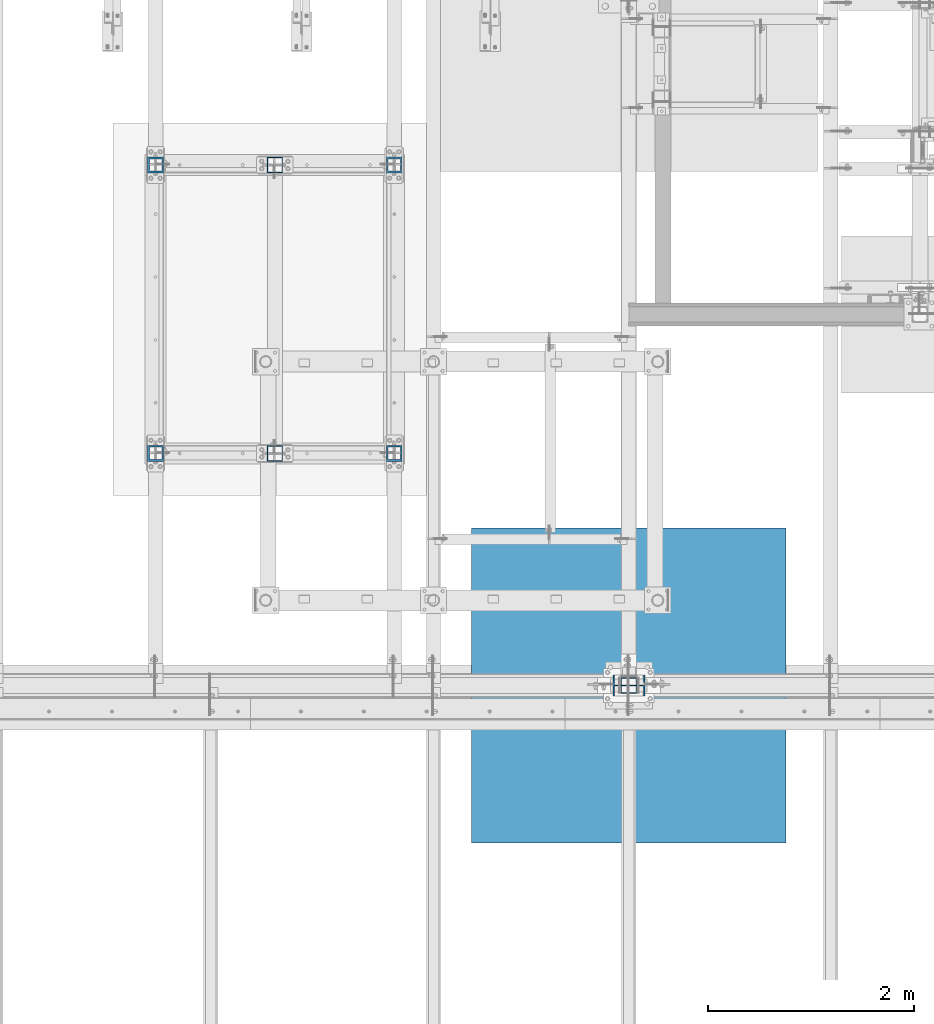
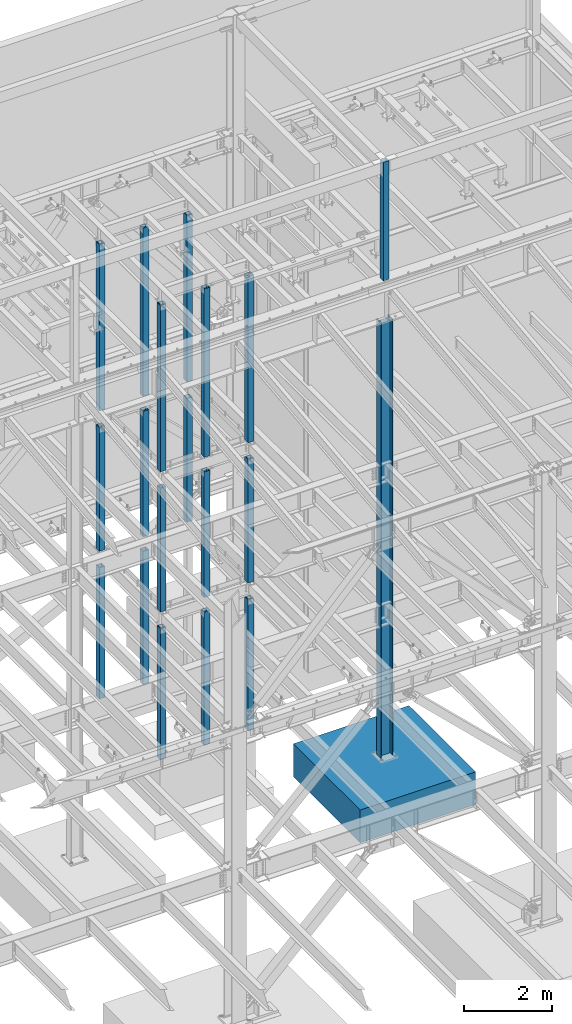
# One storey, part 370 of 1179: 20 columns, 20 elements without a shape of their own.
"""IFC2X3 building model written with IfcOpenShell, lengths in millimetres."""

import ifcopenshell
import ifcopenshell.guid

model = None  # the IFC model being written
_history = None  # IfcOwnerHistory: only IFC2X3 demands one
_inside = {}  # id of a spatial element -> (the spatial element, [elements in it])
_under = {}  # id of a project, library or spatial element -> (it, [spatial elements below it])
_declared = {}  # id of a project -> (the project, [libraries it declares])
_typed = {}  # id of a type object -> (the type object, [elements of that type])
_made_of = {}  # id of a material, layer set ... -> (it, [elements and type objects made of it])


def new_model(schema):
    """Start an empty IFC model of exactly this schema.

    Asked for "IFC4X3", IfcOpenShell would pick the latest addendum, in which some entities
    have other attributes; the version numbers below select the first issue.
    IFC2X3 requires an IfcOwnerHistory on every rooted entity: one is made here for all.
    """
    global model, _history
    if schema == "IFC4X3":
        model = ifcopenshell.file(schema_version=(4, 3, 0, 0))
    else:
        model = ifcopenshell.file(schema=schema)
    _inside.clear()
    _under.clear()
    _declared.clear()
    _typed.clear()
    _made_of.clear()
    _history = None
    if model.schema == "IFC2X3":
        org = make("IfcOrganization", Name="unknown")
        user = make(
            "IfcPersonAndOrganization",
            ThePerson=make("IfcPerson", FamilyName="unknown"),
            TheOrganization=org,
        )
        app = make(
            "IfcApplication",
            ApplicationDeveloper=org,
            Version="unknown",
            ApplicationFullName="unknown",
            ApplicationIdentifier="unknown",
        )
        _history = make(
            "IfcOwnerHistory",
            OwningUser=user,
            OwningApplication=app,
            ChangeAction="ADDED",
            CreationDate=0,
        )
    return model


def make(cls, **values):
    """One entity of the class cls with the attributes given. An attribute that is None is left unset."""
    return model.create_entity(
        cls, **{name: value for name, value in values.items() if value is not None}
    )


def rooted(cls, **values):
    """An entity with a GlobalId (a new one), such as an element, a storey or a relation."""
    return make(cls, GlobalId=ifcopenshell.guid.new(), OwnerHistory=_history, **values)


def si_unit(unit_type, name, prefix=None):
    """IfcSIUnit, for example si_unit("LENGTHUNIT", "METRE", prefix="MILLI")."""
    return make("IfcSIUnit", UnitType=unit_type, Prefix=prefix, Name=name)


def assignment(units):
    """IfcUnitAssignment: the units of a project."""
    return None if units is None else make("IfcUnitAssignment", Units=units)


def point(xyz):
    """IfcCartesianPoint."""
    return None if xyz is None else make("IfcCartesianPoint", Coordinates=xyz)


def direction(xyz):
    """IfcDirection."""
    return None if xyz is None else make("IfcDirection", DirectionRatios=xyz)


def frame(location, z_axis=None, x_axis=None):
    """IfcAxis2Placement3D, a coordinate frame: its origin and axes. An axis left out is left unset."""
    return make(
        "IfcAxis2Placement3D",
        Location=point(location),
        Axis=direction(z_axis),
        RefDirection=direction(x_axis),
    )


def origin_with_axes():
    """The frame at (0, 0, 0) with the z axis (0, 0, 1) and the x axis (1, 0, 0) written out."""
    return frame((0.0, 0.0, 0.0), z_axis=(0.0, 0.0, 1.0), x_axis=(1.0, 0.0, 0.0))


def place(relative_to, where):
    """IfcLocalPlacement: puts the frame where relative to a parent placement (None: the world)."""
    return make(
        "IfcLocalPlacement", PlacementRelTo=relative_to, RelativePlacement=where
    )


def context(
    kind, dimensions, precision=None, world=None, true_north=None, identifier=None
):
    """IfcGeometricRepresentationContext, for example the 3D "Model" context."""
    return make(
        "IfcGeometricRepresentationContext",
        ContextIdentifier=identifier,
        ContextType=kind,
        CoordinateSpaceDimension=dimensions,
        Precision=precision,
        WorldCoordinateSystem=world,
        TrueNorth=true_north,
    )


def subcontext(parent, identifier, kind, view, scale=None):
    """IfcGeometricRepresentationSubContext, for example "Body" below "Model"."""
    return make(
        "IfcGeometricRepresentationSubContext",
        ContextIdentifier=identifier,
        ContextType=kind,
        ParentContext=parent,
        TargetScale=scale,
        TargetView=view,
    )


def project(units=None, contexts=None):
    """IfcProject with its units and contexts."""
    return rooted(
        "IfcProject",
        Name="project",
        RepresentationContexts=contexts,
        UnitsInContext=assignment(units),
    )


def spatial(cls, under=None, at=None, **own):
    """A site, building, storey or space (cls), placed at a placement, below another one or the project."""
    s = rooted(cls, ObjectPlacement=at, **own)
    if under is not None:
        _under.setdefault(under.id(), (under, []))[1].append(s)
    return s


def faces_of(points, faces, orient=None, outer=None):
    """IfcFace entities. A face is a list of loops; a loop is a list of indices into points, from 0.

    orient and outer hold one flag for each loop. By default every Orientation is true, the
    first loop of a face is its IfcFaceOuterBound and the others are IfcFaceBound.
    """
    made = []
    for i, loops in enumerate(faces):
        bounds = []
        for j, loop in enumerate(loops):
            is_outer = j == 0 if outer is None else outer[i][j]
            bounds.append(
                make(
                    "IfcFaceOuterBound" if is_outer else "IfcFaceBound",
                    Bound=make("IfcPolyLoop", Polygon=[points[k] for k in loop]),
                    Orientation=True if orient is None else orient[i][j],
                )
            )
        made.append(make("IfcFace", Bounds=bounds))
    return made


def faceted_brep(points, faces, orient=None, outer=None, voids=None):
    """IfcFacetedBrep: a solid bounded by flat faces; with voids (closed shells), ...WithVoids."""
    shared = [point(p) for p in points]
    hull = make("IfcClosedShell", CfsFaces=faces_of(shared, faces, orient, outer))
    if voids is None:
        return make("IfcFacetedBrep", Outer=hull)
    return make(
        "IfcFacetedBrepWithVoids",
        Outer=hull,
        Voids=[
            make(cls, CfsFaces=faces_of(shared, fs, o, b)) for cls, fs, o, b in voids
        ],
    )


def shape(context_of_items, identifier, shape_type, items):
    """IfcShapeRepresentation: the items that make up one representation, for example the "Body"."""
    return make(
        "IfcShapeRepresentation",
        ContextOfItems=context_of_items,
        RepresentationIdentifier=identifier,
        RepresentationType=shape_type,
        Items=items,
    )


def material(Name=None, Category=None):
    """IfcMaterial."""
    return make("IfcMaterial", Name=Name, Category=Category)


def made_of(thing, what):
    """Note that an element or type object is made of a material, layer set ...; save() writes the relation."""
    if what is not None:
        _made_of.setdefault(what.id(), (what, []))[1].append(thing)
    return thing


def type_object(cls, material=None, **own):
    """A type object (cls), such as IfcWallType, which elements share."""
    return made_of(rooted(cls, **own), material)


def element(
    cls,
    number,
    at=None,
    inside=None,
    cuts=None,
    type_object=None,
    material=None,
    context=None,
    identifier="Body",
    shape_type=None,
    held_by="IfcProductDefinitionShape",
    body=None,
    shapes=None,
    **own,
):
    """One element of the class cls, such as IfcWall. Its Tag is "e" and its number.

    at: its placement. inside: the storey or other place that contains it. cuts: it is an
    opening in that element (IfcRelVoidsElement). A single representation is given by context,
    identifier, shape_type and body (its items); several are given by shapes. held_by: the class
    of the entity that holds the representations. save() writes the other relations.
    """
    e = rooted(cls, Tag="e%d" % number, ObjectPlacement=at, **own)
    if body is not None:
        shapes = [shape(context, identifier, shape_type, body)]
    if shapes is not None:
        e.Representation = make(held_by, Representations=shapes)
    if inside is not None:
        _inside.setdefault(inside.id(), (inside, []))[1].append(e)
    if cuts is not None:
        rooted(
            "IfcRelVoidsElement", RelatingBuildingElement=cuts, RelatedOpeningElement=e
        )
    if type_object is not None:
        _typed.setdefault(type_object.id(), (type_object, []))[1].append(e)
    return made_of(e, material)


def aggregate(whole, parts):
    """IfcRelAggregates: a whole, such as a stair, and the parts it consists of."""
    return rooted("IfcRelAggregates", RelatingObject=whole, RelatedObjects=parts)


def save(model, path):
    """Write the relations noted so far, then the file.

    IfcRelAggregates (storeys below a building ...), IfcRelContainedInSpatialStructure (elements
    in a storey), IfcRelDefinesByType, IfcRelAssociatesMaterial and IfcRelDeclares: one each for
    every whole, place, type object, material and project.
    """
    for whole, parts in _under.values():
        aggregate(whole, parts)
    for where, things in _inside.values():
        rooted(
            "IfcRelContainedInSpatialStructure",
            RelatedElements=things,
            RelatingStructure=where,
        )
    for kind, things in _typed.values():
        rooted("IfcRelDefinesByType", RelatedObjects=things, RelatingType=kind)
    for what, things in _made_of.values():
        rooted("IfcRelAssociatesMaterial", RelatedObjects=things, RelatingMaterial=what)
    for by, libraries in _declared.values():
        rooted("IfcRelDeclares", RelatingContext=by, RelatedDefinitions=libraries)
    model.write(path)


model = new_model("IFC2X3")

# Units and contexts
model_context = context("Model", 3, precision=1e-05, world=origin_with_axes())
body_context = subcontext(model_context, "Body", "Model", "MODEL_VIEW")
ifc_project = project(units=[si_unit("LENGTHUNIT", "METRE", prefix="MILLI"), si_unit("AREAUNIT", "SQUARE_METRE"), si_unit("VOLUMEUNIT", "CUBIC_METRE"), si_unit("MASSUNIT", "GRAM", prefix="KILO"), si_unit("TIMEUNIT", "SECOND"), si_unit("PLANEANGLEUNIT", "RADIAN"), si_unit("SOLIDANGLEUNIT", "STERADIAN"), si_unit("THERMODYNAMICTEMPERATUREUNIT", "DEGREE_CELSIUS"), si_unit("LUMINOUSINTENSITYUNIT", "LUMEN")], contexts=[model_context])

# Site, building, storey
site_placement = place(None, origin_with_axes())
site = spatial("IfcSite", under=ifc_project, at=site_placement, CompositionType="ELEMENT")
building_placement = place(site_placement, origin_with_axes())
building = spatial("IfcBuilding", under=site, at=building_placement, Name="Undefined", CompositionType="ELEMENT")
storey_placement = place(building_placement, origin_with_axes())
storey = spatial("IfcBuildingStorey", under=building, at=storey_placement, Name="Undefined", CompositionType="ELEMENT", Elevation=0.0)

# Assembly, column
assembly_1_placement = place(storey_placement, origin_with_axes())
assembly_1 = element("IfcElementAssembly", 1, at=assembly_1_placement, inside=storey, Name="COLUMN", AssemblyPlace="NOTDEFINED", PredefinedType="RIGID_FRAME")
ifc_material_1 = material()
column_type_1 = type_object("IfcColumnType", Name="HSS6X6X3/8", PredefinedType="NOTDEFINED")
column_1_placement = place(assembly_1_placement, frame((13030.2, 36639.5, 4102.1), z_axis=(0.0, 1.0, 0.0), x_axis=(0.0, 0.0, 1.0)))
column_1 = element("IfcColumn", 2, at=column_1_placement, type_object=column_type_1, material=ifc_material_1, Name="COLUMN", ObjectType="HSS6X6X3/8", context=body_context, shape_type="Brep", body=[
    faceted_brep([(19.0500000000002, 66.6749999999993, -66.6749999999993), (19.0500000000002, -66.6749999999993, -66.6749999999993), (3524.25, -66.6749999999993, -66.6749999999993), (3524.25, 66.6749999999993, -66.6749999999993), (19.0500000000002, -66.6749999999993, 66.6749999999993), (3524.25, -66.6749999999993, 66.6749999999993), (19.0500000000002, 66.6749999999993, 66.6749999999993), (3524.25, 66.6749999999993, 66.6749999999993), (19.0500000000002, 76.2000000000007, -76.2000000000007), (19.0500000000002, 76.2000000000007, 76.2000000000007), (3524.25, 76.2000000000007, 76.2000000000007), (3524.25, 76.2000000000007, -76.2000000000007), (19.0500000000002, -76.2000000000007, 76.2000000000007), (3524.25, -76.2000000000007, 76.2000000000007), (19.0500000000002, -76.2000000000007, -76.2000000000007), (3524.25, -76.2000000000007, -76.2000000000007)], [[[0, 1, 2, 3]], [[1, 4, 5, 2]], [[4, 6, 7, 5]], [[6, 0, 3, 7]], [[8, 9, 10, 11]], [[9, 12, 13, 10]], [[12, 14, 15, 13]], [[14, 8, 11, 15]], [[13, 15, 11, 10], [5, 7, 3, 2]], [[14, 12, 9, 8], [6, 4, 1, 0]]]),
])
aggregate(assembly_1, [column_1])

assembly_2_placement = place(storey_placement, origin_with_axes())
assembly_2 = element("IfcElementAssembly", 3, at=assembly_2_placement, inside=storey, Name="COLUMN", AssemblyPlace="NOTDEFINED", PredefinedType="RIGID_FRAME")
column_2_placement = place(assembly_2_placement, frame((13030.2, 39433.5, 4102.1), z_axis=(0.0, 1.0, 0.0), x_axis=(0.0, 0.0, 1.0)))
column_2 = element("IfcColumn", 4, at=column_2_placement, type_object=column_type_1, material=ifc_material_1, Name="COLUMN", ObjectType="HSS6X6X3/8", context=body_context, shape_type="Brep", body=[
    faceted_brep([(19.0500000000002, 66.6749999999993, -66.6749999999993), (19.0500000000002, -66.6749999999993, -66.6749999999993), (3524.25, -66.6749999999993, -66.6749999999993), (3524.25, 66.6749999999993, -66.6749999999993), (19.0500000000002, -66.6749999999993, 66.6749999999993), (3524.25, -66.6749999999993, 66.6749999999993), (19.0500000000002, 66.6749999999993, 66.6749999999993), (3524.25, 66.6749999999993, 66.6749999999993), (19.0500000000002, 76.2000000000007, -76.2000000000007), (19.0500000000002, 76.2000000000007, 76.2000000000007), (3524.25, 76.2000000000007, 76.2000000000007), (3524.25, 76.2000000000007, -76.2000000000007), (19.0500000000002, -76.2000000000007, 76.2000000000007), (3524.25, -76.2000000000007, 76.2000000000007), (19.0500000000002, -76.2000000000007, -76.2000000000007), (3524.25, -76.2000000000007, -76.2000000000007)], [[[0, 1, 2, 3]], [[1, 4, 5, 2]], [[4, 6, 7, 5]], [[6, 0, 3, 7]], [[8, 9, 10, 11]], [[9, 12, 13, 10]], [[12, 14, 15, 13]], [[14, 8, 11, 15]], [[13, 15, 11, 10], [5, 7, 3, 2]], [[14, 12, 9, 8], [6, 4, 1, 0]]]),
])
aggregate(assembly_2, [column_2])

assembly_3_placement = place(storey_placement, origin_with_axes())
assembly_3 = element("IfcElementAssembly", 5, at=assembly_3_placement, inside=storey, Name="COLUMN", AssemblyPlace="NOTDEFINED", PredefinedType="RIGID_FRAME")
column_3_placement = place(assembly_3_placement, frame((13030.2, 36639.5, 8013.7), z_axis=(0.0, 1.0, 0.0), x_axis=(0.0, 0.0, 1.0)))
column_3 = element("IfcColumn", 6, at=column_3_placement, type_object=column_type_1, material=ifc_material_1, Name="COLUMN", ObjectType="HSS6X6X3/8", context=body_context, shape_type="Brep", body=[
    faceted_brep([(19.0500000000002, 66.6749999999993, -66.6749999999993), (19.0500000000002, -66.6749999999993, -66.6749999999993), (4718.05, -66.6749999999993, -66.6750000000029), (4718.05, 66.6749999999993, -66.6750000000029), (19.0500000000002, -66.6749999999993, 66.6749999999993), (4718.05, -66.6749999999993, 66.6750000000029), (19.0500000000002, 66.6749999999993, 66.6749999999993), (4718.05, 66.6749999999993, 66.6750000000029), (19.0500000000002, 76.2000000000007, -76.2000000000007), (19.0500000000002, 76.2000000000007, 76.2000000000007), (4718.05, 76.2000000000007, 76.1999999999971), (4718.05, 76.2000000000007, -76.1999999999971), (19.0500000000002, -76.2000000000007, 76.2000000000007), (4718.05, -76.2000000000007, 76.1999999999971), (19.0500000000002, -76.2000000000007, -76.2000000000007), (4718.05, -76.2000000000007, -76.1999999999971)], [[[0, 1, 2, 3]], [[1, 4, 5, 2]], [[4, 6, 7, 5]], [[6, 0, 3, 7]], [[8, 9, 10, 11]], [[9, 12, 13, 10]], [[12, 14, 15, 13]], [[14, 8, 11, 15]], [[13, 15, 11, 10], [5, 7, 3, 2]], [[14, 12, 9, 8], [6, 4, 1, 0]]]),
])
aggregate(assembly_3, [column_3])

assembly_4_placement = place(storey_placement, origin_with_axes())
assembly_4 = element("IfcElementAssembly", 7, at=assembly_4_placement, inside=storey, Name="COLUMN", AssemblyPlace="NOTDEFINED", PredefinedType="RIGID_FRAME")
column_4_placement = place(assembly_4_placement, frame((13030.2, 39433.5, 8013.7), z_axis=(0.0, 1.0, 0.0), x_axis=(0.0, 0.0, 1.0)))
column_4 = element("IfcColumn", 8, at=column_4_placement, type_object=column_type_1, material=ifc_material_1, Name="COLUMN", ObjectType="HSS6X6X3/8", context=body_context, shape_type="Brep", body=[
    faceted_brep([(19.0500000000002, 66.6749999999993, -66.6749999999993), (19.0500000000002, -66.6749999999993, -66.6749999999993), (4718.05, -66.6749999999993, -66.6750000000029), (4718.05, 66.6749999999993, -66.6750000000029), (19.0500000000002, -66.6749999999993, 66.6749999999993), (4718.05, -66.6749999999993, 66.6750000000029), (19.0500000000002, 66.6749999999993, 66.6749999999993), (4718.05, 66.6749999999993, 66.6750000000029), (19.0500000000002, 76.2000000000007, -76.2000000000007), (19.0500000000002, 76.2000000000007, 76.2000000000007), (4718.05, 76.2000000000007, 76.1999999999971), (4718.05, 76.2000000000007, -76.1999999999971), (19.0500000000002, -76.2000000000007, 76.2000000000007), (4718.05, -76.2000000000007, 76.1999999999971), (19.0500000000002, -76.2000000000007, -76.2000000000007), (4718.05, -76.2000000000007, -76.1999999999971)], [[[0, 1, 2, 3]], [[1, 4, 5, 2]], [[4, 6, 7, 5]], [[6, 0, 3, 7]], [[8, 9, 10, 11]], [[9, 12, 13, 10]], [[12, 14, 15, 13]], [[14, 8, 11, 15]], [[13, 15, 11, 10], [5, 7, 3, 2]], [[14, 12, 9, 8], [6, 4, 1, 0]]]),
])
aggregate(assembly_4, [column_4])

assembly_5_placement = place(storey_placement, origin_with_axes())
assembly_5 = element("IfcElementAssembly", 9, at=assembly_5_placement, inside=storey, Name="COLUMN", AssemblyPlace="NOTDEFINED", PredefinedType="RIGID_FRAME")
column_5_placement = place(assembly_5_placement, frame((13030.2, 36639.5, 0.0), z_axis=(0.0, 1.0, 0.0), x_axis=(0.0, 0.0, 1.0)))
column_5 = element("IfcColumn", 10, at=column_5_placement, type_object=column_type_1, material=ifc_material_1, Name="COLUMN", ObjectType="HSS6X6X3/8", context=body_context, shape_type="Brep", body=[
    faceted_brep([(0.0, 66.6749999999993, -66.6750000000029), (0.0, -66.6749999999993, -66.6750000000029), (3714.75000000008, -66.6749999999993, -66.6749999999993), (3714.75000000008, 66.6749999999993, -66.6749999999993), (0.0, -66.6749999999993, 66.6750000000029), (3714.75000000008, -66.6749999999993, 66.6749999999993), (0.0, 66.6749999999993, 66.6750000000029), (3714.75000000008, 66.6749999999993, 66.6749999999993), (6.54836185276508e-11, 76.2, -76.1999999999998), (6.54836185276508e-11, 76.2, 76.1999999999998), (3714.75000000008, 76.2000000000007, 76.2000000000007), (3714.75000000008, 76.2000000000007, -76.2000000000007), (-6.54836185276508e-11, -76.2, 76.1999999999998), (3714.75000000008, -76.2000000000007, 76.2000000000007), (-6.54836185276508e-11, -76.2, -76.1999999999998), (3714.75000000008, -76.2000000000007, -76.2000000000007)], [[[0, 1, 2, 3]], [[1, 4, 5, 2]], [[4, 6, 7, 5]], [[6, 0, 3, 7]], [[8, 9, 10, 11]], [[9, 12, 13, 10]], [[12, 14, 15, 13]], [[14, 8, 11, 15]], [[13, 15, 11, 10], [5, 7, 3, 2]], [[14, 12, 9, 8], [6, 4, 1, 0]]]),
])
aggregate(assembly_5, [column_5])

assembly_6_placement = place(storey_placement, origin_with_axes())
assembly_6 = element("IfcElementAssembly", 11, at=assembly_6_placement, inside=storey, Name="COLUMN", AssemblyPlace="NOTDEFINED", PredefinedType="RIGID_FRAME")
column_6_placement = place(assembly_6_placement, frame((13030.2, 39433.5, 0.0), z_axis=(0.0, 1.0, 0.0), x_axis=(0.0, 0.0, 1.0)))
column_6 = element("IfcColumn", 12, at=column_6_placement, type_object=column_type_1, material=ifc_material_1, Name="COLUMN", ObjectType="HSS6X6X3/8", context=body_context, shape_type="Brep", body=[
    faceted_brep([(0.0, 66.6749999999993, -66.6750000000029), (0.0, -66.6749999999993, -66.6750000000029), (3714.75000000008, -66.6749999999993, -66.6749999999993), (3714.75000000008, 66.6749999999993, -66.6749999999993), (0.0, -66.6749999999993, 66.6750000000029), (3714.75000000008, -66.6749999999993, 66.6749999999993), (0.0, 66.6749999999993, 66.6750000000029), (3714.75000000008, 66.6749999999993, 66.6749999999993), (6.54836185276508e-11, 76.2, -76.1999999999998), (6.54836185276508e-11, 76.2, 76.1999999999998), (3714.75000000008, 76.2000000000007, 76.2000000000007), (3714.75000000008, 76.2000000000007, -76.2000000000007), (-6.54836185276508e-11, -76.2, 76.1999999999998), (3714.75000000008, -76.2000000000007, 76.2000000000007), (-6.54836185276508e-11, -76.2, -76.1999999999998), (3714.75000000008, -76.2000000000007, -76.2000000000007)], [[[0, 1, 2, 3]], [[1, 4, 5, 2]], [[4, 6, 7, 5]], [[6, 0, 3, 7]], [[8, 9, 10, 11]], [[9, 12, 13, 10]], [[12, 14, 15, 13]], [[14, 8, 11, 15]], [[13, 15, 11, 10], [5, 7, 3, 2]], [[14, 12, 9, 8], [6, 4, 1, 0]]]),
])
aggregate(assembly_6, [column_6])

assembly_7_placement = place(storey_placement, origin_with_axes())
assembly_7 = element("IfcElementAssembly", 13, at=assembly_7_placement, inside=storey, Name="COLUMN", AssemblyPlace="NOTDEFINED", PredefinedType="RIGID_FRAME")
column_type_2 = type_object("IfcColumnType", Name="HSS6X6X5/8", PredefinedType="NOTDEFINED")
column_7_placement = place(assembly_7_placement, frame((11874.5, 39433.5, 4102.1), z_axis=(0.0, 1.0, 0.0), x_axis=(0.0, 0.0, 1.0)))
column_7 = element("IfcColumn", 14, at=column_7_placement, type_object=column_type_2, material=ifc_material_1, Name="COLUMN", ObjectType="HSS6X6X5/8", context=body_context, shape_type="Brep", body=[
    faceted_brep([(19.050000000002, 60.3250000000007, -60.3249999999971), (19.050000000002, -60.3250000000007, -60.3249999999971), (3470.275, -60.3250000000007, -60.3249999999971), (3470.275, 60.3250000000007, -60.3249999999971), (19.050000000002, -60.3250000000007, 60.3249999999971), (3470.275, -60.3250000000007, 60.3249999999971), (19.050000000002, 60.3250000000007, 60.3249999999971), (3470.275, 60.3250000000007, 60.3249999999971), (19.0500000000002, 76.2000000000007, -76.2000000000007), (19.0500000000002, 76.2000000000007, 76.2000000000007), (3470.275, 76.2000000000007, 76.1999999999971), (3470.275, 76.2000000000007, -76.1999999999971), (19.0500000000002, -76.2000000000007, 76.2000000000007), (3470.275, -76.2000000000007, 76.1999999999971), (19.0500000000002, -76.2000000000007, -76.2000000000007), (3470.275, -76.2000000000007, -76.1999999999971)], [[[0, 1, 2, 3]], [[1, 4, 5, 2]], [[4, 6, 7, 5]], [[6, 0, 3, 7]], [[8, 9, 10, 11]], [[9, 12, 13, 10]], [[12, 14, 15, 13]], [[14, 8, 11, 15]], [[13, 15, 11, 10], [5, 7, 3, 2]], [[14, 12, 9, 8], [6, 4, 1, 0]]]),
])
aggregate(assembly_7, [column_7])

assembly_8_placement = place(storey_placement, origin_with_axes())
assembly_8 = element("IfcElementAssembly", 15, at=assembly_8_placement, inside=storey, Name="COLUMN", AssemblyPlace="NOTDEFINED", PredefinedType="RIGID_FRAME")
column_8_placement = place(assembly_8_placement, frame((14185.9, 39433.5, 4102.1), z_axis=(0.0, 1.0, 0.0), x_axis=(0.0, 0.0, 1.0)))
column_8 = element("IfcColumn", 16, at=column_8_placement, type_object=column_type_2, material=ifc_material_1, Name="COLUMN", ObjectType="HSS6X6X5/8", context=body_context, shape_type="Brep", body=[
    faceted_brep([(19.050000000002, 60.3250000000007, -60.3249999999971), (19.050000000002, -60.3250000000007, -60.3249999999971), (3470.275, -60.3250000000007, -60.3249999999971), (3470.275, 60.3250000000007, -60.3249999999971), (19.050000000002, -60.3250000000007, 60.3249999999971), (3470.275, -60.3250000000007, 60.3249999999971), (19.050000000002, 60.3250000000007, 60.3249999999971), (3470.275, 60.3250000000007, 60.3249999999971), (19.0500000000002, 76.2000000000007, -76.2000000000007), (19.0500000000002, 76.2000000000007, 76.2000000000007), (3470.275, 76.2000000000007, 76.1999999999971), (3470.275, 76.2000000000007, -76.1999999999971), (19.0500000000002, -76.2000000000007, 76.2000000000007), (3470.275, -76.2000000000007, 76.1999999999971), (19.0500000000002, -76.2000000000007, -76.2000000000007), (3470.275, -76.2000000000007, -76.1999999999971)], [[[0, 1, 2, 3]], [[1, 4, 5, 2]], [[4, 6, 7, 5]], [[6, 0, 3, 7]], [[8, 9, 10, 11]], [[9, 12, 13, 10]], [[12, 14, 15, 13]], [[14, 8, 11, 15]], [[13, 15, 11, 10], [5, 7, 3, 2]], [[14, 12, 9, 8], [6, 4, 1, 0]]]),
])
aggregate(assembly_8, [column_8])

assembly_9_placement = place(storey_placement, origin_with_axes())
assembly_9 = element("IfcElementAssembly", 17, at=assembly_9_placement, inside=storey, Name="COLUMN", AssemblyPlace="NOTDEFINED", PredefinedType="RIGID_FRAME")
column_9_placement = place(assembly_9_placement, frame((14185.9, 36639.5, 8013.7), z_axis=(0.0, 1.0, 0.0), x_axis=(0.0, 0.0, 1.0)))
column_9 = element("IfcColumn", 18, at=column_9_placement, type_object=column_type_2, material=ifc_material_1, Name="COLUMN", ObjectType="HSS6X6X5/8", context=body_context, shape_type="Brep", body=[
    faceted_brep([(19.050000000002, 60.3250000000007, -60.3249999999971), (19.050000000002, -60.3250000000007, -60.3249999999971), (4664.075, -60.3250000000007, -60.3249999999971), (4664.075, 60.3250000000007, -60.3249999999971), (19.050000000002, -60.3250000000007, 60.3249999999971), (4664.075, -60.3250000000007, 60.3249999999971), (19.050000000002, 60.3250000000007, 60.3249999999971), (4664.075, 60.3250000000007, 60.3249999999971), (19.0500000000002, 76.2000000000007, -76.2000000000007), (19.0500000000002, 76.2000000000007, 76.2000000000007), (4664.075, 76.2000000000007, 76.1999999999971), (4664.075, 76.2000000000007, -76.1999999999971), (19.0500000000002, -76.2000000000007, 76.2000000000007), (4664.075, -76.2000000000007, 76.1999999999971), (19.0500000000002, -76.2000000000007, -76.2000000000007), (4664.075, -76.2000000000007, -76.1999999999971)], [[[0, 1, 2, 3]], [[1, 4, 5, 2]], [[4, 6, 7, 5]], [[6, 0, 3, 7]], [[8, 9, 10, 11]], [[9, 12, 13, 10]], [[12, 14, 15, 13]], [[14, 8, 11, 15]], [[13, 15, 11, 10], [5, 7, 3, 2]], [[14, 12, 9, 8], [6, 4, 1, 0]]]),
])
aggregate(assembly_9, [column_9])

assembly_10_placement = place(storey_placement, origin_with_axes())
assembly_10 = element("IfcElementAssembly", 19, at=assembly_10_placement, inside=storey, Name="COLUMN", AssemblyPlace="NOTDEFINED", PredefinedType="RIGID_FRAME")
column_10_placement = place(assembly_10_placement, frame((11874.5, 36639.5, 8013.7), z_axis=(0.0, 1.0, 0.0), x_axis=(0.0, 0.0, 1.0)))
column_10 = element("IfcColumn", 20, at=column_10_placement, type_object=column_type_2, material=ifc_material_1, Name="COLUMN", ObjectType="HSS6X6X5/8", context=body_context, shape_type="Brep", body=[
    faceted_brep([(19.050000000002, 60.3250000000007, -60.3249999999971), (19.050000000002, -60.3250000000007, -60.3249999999971), (4664.075, -60.3250000000007, -60.3249999999971), (4664.075, 60.3250000000007, -60.3249999999971), (19.050000000002, -60.3250000000007, 60.3249999999971), (4664.075, -60.3250000000007, 60.3249999999971), (19.050000000002, 60.3250000000007, 60.3249999999971), (4664.075, 60.3250000000007, 60.3249999999971), (19.0500000000002, 76.2000000000007, -76.2000000000007), (19.0500000000002, 76.2000000000007, 76.2000000000007), (4664.075, 76.2000000000007, 76.1999999999971), (4664.075, 76.2000000000007, -76.1999999999971), (19.0500000000002, -76.2000000000007, 76.2000000000007), (4664.075, -76.2000000000007, 76.1999999999971), (19.0500000000002, -76.2000000000007, -76.2000000000007), (4664.075, -76.2000000000007, -76.1999999999971)], [[[0, 1, 2, 3]], [[1, 4, 5, 2]], [[4, 6, 7, 5]], [[6, 0, 3, 7]], [[8, 9, 10, 11]], [[9, 12, 13, 10]], [[12, 14, 15, 13]], [[14, 8, 11, 15]], [[13, 15, 11, 10], [5, 7, 3, 2]], [[14, 12, 9, 8], [6, 4, 1, 0]]]),
])
aggregate(assembly_10, [column_10])

assembly_11_placement = place(storey_placement, origin_with_axes())
assembly_11 = element("IfcElementAssembly", 21, at=assembly_11_placement, inside=storey, Name="COLUMN", AssemblyPlace="NOTDEFINED", PredefinedType="RIGID_FRAME")
column_11_placement = place(assembly_11_placement, frame((14185.9, 39433.5, 8013.7), z_axis=(0.0, 1.0, 0.0), x_axis=(0.0, 0.0, 1.0)))
column_11 = element("IfcColumn", 22, at=column_11_placement, type_object=column_type_2, material=ifc_material_1, Name="COLUMN", ObjectType="HSS6X6X5/8", context=body_context, shape_type="Brep", body=[
    faceted_brep([(19.050000000002, 60.3250000000007, -60.3249999999971), (19.050000000002, -60.3250000000007, -60.3249999999971), (4664.075, -60.3250000000007, -60.3249999999971), (4664.075, 60.3250000000007, -60.3249999999971), (19.050000000002, -60.3250000000007, 60.3249999999971), (4664.075, -60.3250000000007, 60.3249999999971), (19.050000000002, 60.3250000000007, 60.3249999999971), (4664.075, 60.3250000000007, 60.3249999999971), (19.0500000000002, 76.2000000000007, -76.2000000000007), (19.0500000000002, 76.2000000000007, 76.2000000000007), (4664.075, 76.2000000000007, 76.1999999999971), (4664.075, 76.2000000000007, -76.1999999999971), (19.0500000000002, -76.2000000000007, 76.2000000000007), (4664.075, -76.2000000000007, 76.1999999999971), (19.0500000000002, -76.2000000000007, -76.2000000000007), (4664.075, -76.2000000000007, -76.1999999999971)], [[[0, 1, 2, 3]], [[1, 4, 5, 2]], [[4, 6, 7, 5]], [[6, 0, 3, 7]], [[8, 9, 10, 11]], [[9, 12, 13, 10]], [[12, 14, 15, 13]], [[14, 8, 11, 15]], [[13, 15, 11, 10], [5, 7, 3, 2]], [[14, 12, 9, 8], [6, 4, 1, 0]]]),
])
aggregate(assembly_11, [column_11])

assembly_12_placement = place(storey_placement, origin_with_axes())
assembly_12 = element("IfcElementAssembly", 23, at=assembly_12_placement, inside=storey, Name="COLUMN", AssemblyPlace="NOTDEFINED", PredefinedType="RIGID_FRAME")
column_12_placement = place(assembly_12_placement, frame((11874.5, 39433.5, 8013.7), z_axis=(0.0, 1.0, 0.0), x_axis=(0.0, 0.0, 1.0)))
column_12 = element("IfcColumn", 24, at=column_12_placement, type_object=column_type_2, material=ifc_material_1, Name="COLUMN", ObjectType="HSS6X6X5/8", context=body_context, shape_type="Brep", body=[
    faceted_brep([(19.050000000002, 60.3250000000007, -60.3249999999971), (19.050000000002, -60.3250000000007, -60.3249999999971), (4664.075, -60.3250000000007, -60.3249999999971), (4664.075, 60.3250000000007, -60.3249999999971), (19.050000000002, -60.3250000000007, 60.3249999999971), (4664.075, -60.3250000000007, 60.3249999999971), (19.050000000002, 60.3250000000007, 60.3249999999971), (4664.075, 60.3250000000007, 60.3249999999971), (19.0500000000002, 76.2000000000007, -76.2000000000007), (19.0500000000002, 76.2000000000007, 76.2000000000007), (4664.075, 76.2000000000007, 76.1999999999971), (4664.075, 76.2000000000007, -76.1999999999971), (19.0500000000002, -76.2000000000007, 76.2000000000007), (4664.075, -76.2000000000007, 76.1999999999971), (19.0500000000002, -76.2000000000007, -76.2000000000007), (4664.075, -76.2000000000007, -76.1999999999971)], [[[0, 1, 2, 3]], [[1, 4, 5, 2]], [[4, 6, 7, 5]], [[6, 0, 3, 7]], [[8, 9, 10, 11]], [[9, 12, 13, 10]], [[12, 14, 15, 13]], [[14, 8, 11, 15]], [[13, 15, 11, 10], [5, 7, 3, 2]], [[14, 12, 9, 8], [6, 4, 1, 0]]]),
])
aggregate(assembly_12, [column_12])

assembly_13_placement = place(storey_placement, origin_with_axes())
assembly_13 = element("IfcElementAssembly", 25, at=assembly_13_placement, inside=storey, Name="COLUMN", AssemblyPlace="NOTDEFINED", PredefinedType="RIGID_FRAME")
column_13_placement = place(assembly_13_placement, frame((14185.9, 36639.5, 4102.1), z_axis=(0.0, 1.0, 0.0), x_axis=(0.0, 0.0, 1.0)))
column_13 = element("IfcColumn", 26, at=column_13_placement, type_object=column_type_2, material=ifc_material_1, Name="COLUMN", ObjectType="HSS6X6X5/8", context=body_context, shape_type="Brep", body=[
    faceted_brep([(19.050000000002, 60.3250000000007, -60.3249999999971), (19.050000000002, -60.3250000000007, -60.3249999999971), (3470.275, -60.3250000000007, -60.3249999999971), (3470.275, 60.3250000000007, -60.3249999999971), (19.050000000002, -60.3250000000007, 60.3249999999971), (3470.275, -60.3250000000007, 60.3249999999971), (19.050000000002, 60.3250000000007, 60.3249999999971), (3470.275, 60.3250000000007, 60.3249999999971), (19.0500000000002, 76.2000000000007, -76.2000000000007), (19.0500000000002, 76.2000000000007, 76.2000000000007), (3470.275, 76.2000000000007, 76.1999999999971), (3470.275, 76.2000000000007, -76.1999999999971), (19.0500000000002, -76.2000000000007, 76.2000000000007), (3470.275, -76.2000000000007, 76.1999999999971), (19.0500000000002, -76.2000000000007, -76.2000000000007), (3470.275, -76.2000000000007, -76.1999999999971)], [[[0, 1, 2, 3]], [[1, 4, 5, 2]], [[4, 6, 7, 5]], [[6, 0, 3, 7]], [[8, 9, 10, 11]], [[9, 12, 13, 10]], [[12, 14, 15, 13]], [[14, 8, 11, 15]], [[13, 15, 11, 10], [5, 7, 3, 2]], [[14, 12, 9, 8], [6, 4, 1, 0]]]),
])
aggregate(assembly_13, [column_13])

assembly_14_placement = place(storey_placement, origin_with_axes())
assembly_14 = element("IfcElementAssembly", 27, at=assembly_14_placement, inside=storey, Name="COLUMN", AssemblyPlace="NOTDEFINED", PredefinedType="RIGID_FRAME")
column_14_placement = place(assembly_14_placement, frame((11874.5, 36639.5, 4102.1), z_axis=(0.0, 1.0, 0.0), x_axis=(0.0, 0.0, 1.0)))
column_14 = element("IfcColumn", 28, at=column_14_placement, type_object=column_type_2, material=ifc_material_1, Name="COLUMN", ObjectType="HSS6X6X5/8", context=body_context, shape_type="Brep", body=[
    faceted_brep([(19.050000000002, 60.3250000000007, -60.3249999999971), (19.050000000002, -60.3250000000007, -60.3249999999971), (3470.275, -60.3250000000007, -60.3249999999971), (3470.275, 60.3250000000007, -60.3249999999971), (19.050000000002, -60.3250000000007, 60.3249999999971), (3470.275, -60.3250000000007, 60.3249999999971), (19.050000000002, 60.3250000000007, 60.3249999999971), (3470.275, 60.3250000000007, 60.3249999999971), (19.0500000000002, 76.2000000000007, -76.2000000000007), (19.0500000000002, 76.2000000000007, 76.2000000000007), (3470.275, 76.2000000000007, 76.1999999999971), (3470.275, 76.2000000000007, -76.1999999999971), (19.0500000000002, -76.2000000000007, 76.2000000000007), (3470.275, -76.2000000000007, 76.1999999999971), (19.0500000000002, -76.2000000000007, -76.2000000000007), (3470.275, -76.2000000000007, -76.1999999999971)], [[[0, 1, 2, 3]], [[1, 4, 5, 2]], [[4, 6, 7, 5]], [[6, 0, 3, 7]], [[8, 9, 10, 11]], [[9, 12, 13, 10]], [[12, 14, 15, 13]], [[14, 8, 11, 15]], [[13, 15, 11, 10], [5, 7, 3, 2]], [[14, 12, 9, 8], [6, 4, 1, 0]]]),
])
aggregate(assembly_14, [column_14])

assembly_15_placement = place(storey_placement, origin_with_axes())
assembly_15 = element("IfcElementAssembly", 29, at=assembly_15_placement, inside=storey, Name="COLUMN", AssemblyPlace="NOTDEFINED", PredefinedType="RIGID_FRAME")
column_15_placement = place(assembly_15_placement, frame((11874.5, 36639.5, 0.0), z_axis=(0.0, 1.0, 0.0), x_axis=(0.0, 0.0, 1.0)))
column_15 = element("IfcColumn", 30, at=column_15_placement, type_object=column_type_2, material=ifc_material_1, Name="COLUMN", ObjectType="HSS6X6X5/8", context=body_context, shape_type="Brep", body=[
    faceted_brep([(0.0, 60.3250000000007, -60.3250000000007), (2.71050543121376e-20, -60.3250000000007, -60.3250000000007), (3660.775, -60.325000001314, -60.3250000000007), (3660.775, 60.3249999986838, -60.3250000000007), (2.71050543121376e-20, -60.3250000000007, 60.3250000000007), (3660.775, -60.325000001314, 60.3250000000007), (0.0, 60.3250000000007, 60.3250000000007), (3660.775, 60.3249999986838, 60.3250000000007), (6.54836185276508e-11, 76.2, -76.1999999999998), (6.54836185276508e-11, 76.2, 76.1999999999998), (3660.775, 76.1999999986838, 76.2000000000007), (3660.775, 76.1999999986838, -76.2000000000007), (-6.54836185276508e-11, -76.2, 76.1999999999998), (3660.775, -76.200000001314, 76.2000000000007), (-6.54836185276508e-11, -76.2, -76.1999999999998), (3660.775, -76.200000001314, -76.2000000000007)], [[[0, 1, 2, 3]], [[1, 4, 5, 2]], [[4, 6, 7, 5]], [[6, 0, 3, 7]], [[8, 9, 10, 11]], [[9, 12, 13, 10]], [[12, 14, 15, 13]], [[14, 8, 11, 15]], [[13, 15, 11, 10], [5, 7, 3, 2]], [[14, 12, 9, 8], [6, 4, 1, 0]]]),
])
aggregate(assembly_15, [column_15])

assembly_16_placement = place(storey_placement, origin_with_axes())
assembly_16 = element("IfcElementAssembly", 31, at=assembly_16_placement, inside=storey, Name="COLUMN", AssemblyPlace="NOTDEFINED", PredefinedType="RIGID_FRAME")
column_16_placement = place(assembly_16_placement, frame((14185.9, 36639.5, 0.0), z_axis=(0.0, 1.0, 0.0), x_axis=(0.0, 0.0, 1.0)))
column_16 = element("IfcColumn", 32, at=column_16_placement, type_object=column_type_2, material=ifc_material_1, Name="COLUMN", ObjectType="HSS6X6X5/8", context=body_context, shape_type="Brep", body=[
    faceted_brep([(0.0, 60.3250000000007, -60.3250000000007), (2.71050543121376e-20, -60.3250000000007, -60.3250000000007), (3660.775, -60.325000001314, -60.3250000000007), (3660.775, 60.3249999986838, -60.3250000000007), (2.71050543121376e-20, -60.3250000000007, 60.3250000000007), (3660.775, -60.325000001314, 60.3250000000007), (0.0, 60.3250000000007, 60.3250000000007), (3660.775, 60.3249999986838, 60.3250000000007), (6.54836185276508e-11, 76.2, -76.1999999999998), (6.54836185276508e-11, 76.2, 76.1999999999998), (3660.775, 76.1999999986838, 76.2000000000007), (3660.775, 76.1999999986838, -76.2000000000007), (-6.54836185276508e-11, -76.2, 76.1999999999998), (3660.775, -76.200000001314, 76.2000000000007), (-6.54836185276508e-11, -76.2, -76.1999999999998), (3660.775, -76.200000001314, -76.2000000000007)], [[[0, 1, 2, 3]], [[1, 4, 5, 2]], [[4, 6, 7, 5]], [[6, 0, 3, 7]], [[8, 9, 10, 11]], [[9, 12, 13, 10]], [[12, 14, 15, 13]], [[14, 8, 11, 15]], [[13, 15, 11, 10], [5, 7, 3, 2]], [[14, 12, 9, 8], [6, 4, 1, 0]]]),
])
aggregate(assembly_16, [column_16])

assembly_17_placement = place(storey_placement, origin_with_axes())
assembly_17 = element("IfcElementAssembly", 33, at=assembly_17_placement, inside=storey, Name="COLUMN", AssemblyPlace="NOTDEFINED", PredefinedType="RIGID_FRAME")
column_17_placement = place(assembly_17_placement, frame((11874.5, 39433.5, 0.0), z_axis=(0.0, 1.0, 0.0), x_axis=(0.0, 0.0, 1.0)))
column_17 = element("IfcColumn", 34, at=column_17_placement, type_object=column_type_2, material=ifc_material_1, Name="COLUMN", ObjectType="HSS6X6X5/8", context=body_context, shape_type="Brep", body=[
    faceted_brep([(0.0, 60.3250000000007, -60.3250000000007), (2.71050543121376e-20, -60.3250000000007, -60.3250000000007), (3660.775, -60.325000001314, -60.3250000000007), (3660.775, 60.3249999986838, -60.3250000000007), (2.71050543121376e-20, -60.3250000000007, 60.3250000000007), (3660.775, -60.325000001314, 60.3250000000007), (0.0, 60.3250000000007, 60.3250000000007), (3660.775, 60.3249999986838, 60.3250000000007), (6.54836185276508e-11, 76.2, -76.1999999999998), (6.54836185276508e-11, 76.2, 76.1999999999998), (3660.775, 76.1999999986838, 76.2000000000007), (3660.775, 76.1999999986838, -76.2000000000007), (-6.54836185276508e-11, -76.2, 76.1999999999998), (3660.775, -76.200000001314, 76.2000000000007), (-6.54836185276508e-11, -76.2, -76.1999999999998), (3660.775, -76.200000001314, -76.2000000000007)], [[[0, 1, 2, 3]], [[1, 4, 5, 2]], [[4, 6, 7, 5]], [[6, 0, 3, 7]], [[8, 9, 10, 11]], [[9, 12, 13, 10]], [[12, 14, 15, 13]], [[14, 8, 11, 15]], [[13, 15, 11, 10], [5, 7, 3, 2]], [[14, 12, 9, 8], [6, 4, 1, 0]]]),
])
aggregate(assembly_17, [column_17])

assembly_18_placement = place(storey_placement, origin_with_axes())
assembly_18 = element("IfcElementAssembly", 35, at=assembly_18_placement, inside=storey, Name="COLUMN", AssemblyPlace="NOTDEFINED", PredefinedType="RIGID_FRAME")
column_type_3 = type_object("IfcColumnType", Name="HSS6X6X1/4", PredefinedType="NOTDEFINED")
column_18_placement = place(assembly_18_placement, frame((16459.2, 34391.6, 13119.1), z_axis=(0.0, 1.0, 0.0), x_axis=(0.0, 0.0, 1.0)))
column_18 = element("IfcColumn", 36, at=column_18_placement, type_object=column_type_3, material=ifc_material_1, Name="COLUMN", ObjectType="HSS6X6X1/4", context=body_context, shape_type="Brep", body=[
    faceted_brep([(0.0, 69.8499999999985, -69.8499999999985), (0.0, -69.8499999999985, -69.8499999999985), (3308.35, -69.8499999999985, -69.8499999999985), (3308.35, 69.8499999999985, -69.8499999999985), (0.0, -69.8499999983651, 69.849999997823), (3308.35, -69.8499999999985, 69.8499999999985), (0.0, 69.8499999983651, 69.849999997823), (3308.35, 69.8499999999985, 69.8499999999985), (6.54836185276508e-11, 76.2, -76.1999999999998), (6.54836185276508e-11, 76.2, 76.1999999999998), (3308.35, 76.2000000000007, 76.1999999999971), (3308.35, 76.2000000000007, -76.1999999999971), (-6.54836185276508e-11, -76.2, 76.1999999999998), (3308.35, -76.2000000000007, 76.1999999999971), (-6.54836185276508e-11, -76.2, -76.1999999999998), (3308.35, -76.2000000000007, -76.1999999999971)], [[[0, 1, 2, 3]], [[1, 4, 5, 2]], [[4, 6, 7, 5]], [[6, 0, 3, 7]], [[8, 9, 10, 11]], [[9, 12, 13, 10]], [[12, 14, 15, 13]], [[14, 8, 11, 15]], [[13, 15, 11, 10], [5, 7, 3, 2]], [[14, 12, 9, 8], [6, 4, 1, 0]]]),
])
aggregate(assembly_18, [column_18])

assembly_19_placement = place(storey_placement, origin_with_axes())
assembly_19 = element("IfcElementAssembly", 37, at=assembly_19_placement, inside=storey, Name="FOOTING", AssemblyPlace="NOTDEFINED", PredefinedType="REINFORCEMENT_UNIT")
ifc_material_2 = material(Name="CONCRETE/3000")
column_type_4 = type_object("IfcColumnType", PredefinedType="NOTDEFINED")
column_19_placement = place(assembly_19_placement, frame((16459.2, 34391.6, -1168.4), z_axis=(-1.0, 0.0, 0.0), x_axis=(0.0, 0.0, 1.0)))
column_19 = element("IfcColumn", 38, at=column_19_placement, type_object=column_type_4, material=ifc_material_2, Name="FOOTING", context=body_context, shape_type="Brep", body=[
    faceted_brep([(0.0, 1524.0, -1524.0), (0.0, 1524.0, 1524.0), (914.4, 1524.0, 1524.0), (914.4, 1524.0, -1524.0), (0.0, -1524.0, 1524.0), (914.4, -1524.0, 1524.0), (0.0, -1524.0, -1524.0), (914.4, -1524.0, -1524.0)], [[[0, 1, 2, 3]], [[1, 4, 5, 2]], [[4, 6, 7, 5]], [[6, 0, 3, 7]], [[5, 7, 3, 2]], [[6, 4, 1, 0]]]),
])
aggregate(assembly_19, [column_19])

assembly_20_placement = place(storey_placement, origin_with_axes())
assembly_20 = element("IfcElementAssembly", 39, at=assembly_20_placement, inside=storey, Name="COLUMN", AssemblyPlace="NOTDEFINED", PredefinedType="RIGID_FRAME")
ifc_material_3 = material(Name="STEEL/A992")
column_type_5 = type_object("IfcColumnType", Name="W12X50", PredefinedType="NOTDEFINED")
column_20_placement = place(assembly_20_placement, frame((16459.2, 34391.6, -355.6), z_axis=(-1.0, 0.0, 0.0), x_axis=(0.0, 0.0, 1.0)))
column_20 = element("IfcColumn", 40, at=column_20_placement, type_object=column_type_5, material=ifc_material_3, Name="COLUMN", ObjectType="W12X50", context=body_context, shape_type="Brep", body=[
    faceted_brep([(190.5, 103.1875, -155.575000000001), (190.5, 103.1875, -139.700000000001), (12357.1, 103.1875, -139.700000000001), (12357.1, 103.1875, -155.575000000001), (190.5, 4.76249999999709, -139.700000000001), (12357.1, 4.76249999999709, -139.700000000001), (190.5, 4.76249999999709, 139.700000000001), (12357.1, 4.76249999999709, 139.700000000001), (190.5, 103.1875, 139.700000000001), (12357.1, 103.1875, 139.700000000001), (190.5, 103.1875, 155.575000000001), (12357.1, 103.1875, 155.575000000001), (190.5, -103.1875, 155.575000000001), (12357.1, -103.1875, 155.575000000001), (190.5, -103.1875, 139.700000000001), (12357.1, -103.1875, 139.700000000001), (190.5, -4.76249999999709, 139.700000000001), (12357.1, -4.76249999999709, 139.700000000001), (190.5, -4.76249999999709, -139.700000000001), (12357.1, -4.76249999999709, -139.700000000001), (190.5, -103.1875, -139.700000000001), (12357.1, -103.1875, -139.700000000001), (190.5, -103.1875, -155.575000000001), (12357.1, -103.1875, -155.575000000001)], [[[0, 1, 2, 3]], [[1, 4, 5, 2]], [[4, 6, 7, 5]], [[6, 8, 9, 7]], [[8, 10, 11, 9]], [[10, 12, 13, 11]], [[12, 14, 15, 13]], [[14, 16, 17, 15]], [[16, 18, 19, 17]], [[18, 20, 21, 19]], [[20, 22, 23, 21]], [[22, 0, 3, 23]], [[5, 7, 9, 11, 13, 15, 17, 19, 21, 23, 3, 2]], [[22, 20, 18, 16, 14, 12, 10, 8, 6, 4, 1, 0]]]),
])
aggregate(assembly_20, [column_20])

save(model, "model.ifc")
